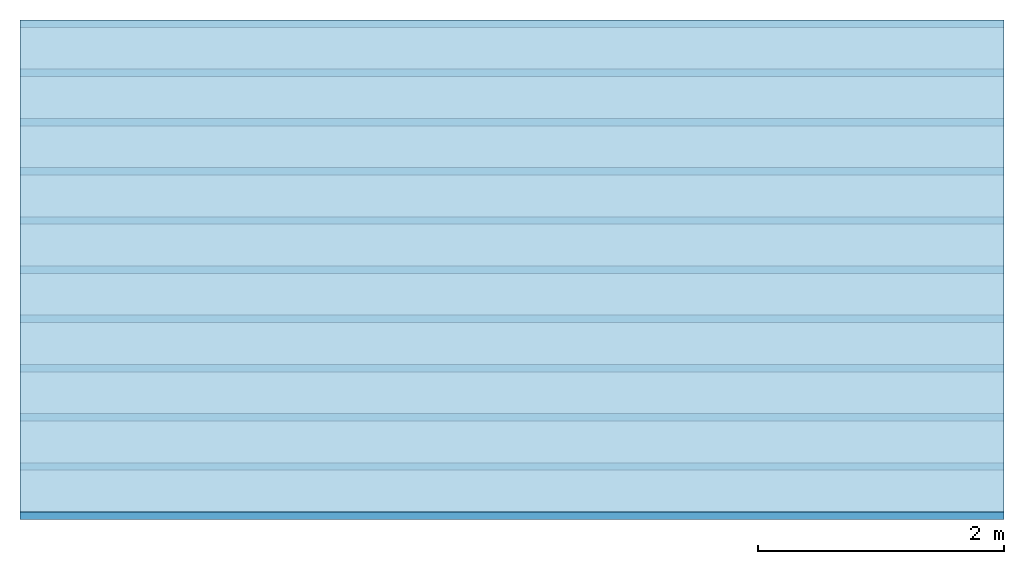
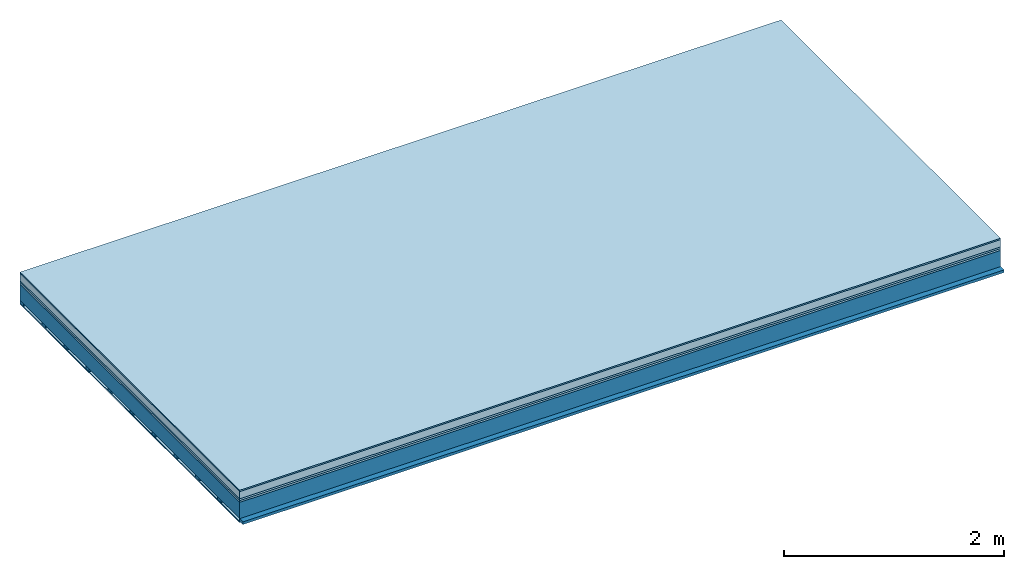
# One storey: 6 plates, 2 members, 1 element without a shape of its own.
"""IFC4 building model written with IfcOpenShell, lengths in metres."""

from ifc_helpers import new_model, si_unit, derived_unit, direction, frame, frame_2d, origin, origin_with_axes, place, context, project, spatial, rectangle, extrude, material, layer, layer_set, type_object, element, aggregate, save


model = new_model("IFC4")

# Units and contexts
plan_context = context("Plan", 3, precision=1e-05, world=origin(), true_north=direction((0.0, 1.0)))
model_context = context("Model", 3, precision=1e-05, world=origin(), true_north=direction((0.0, 1.0)))
ifc_project = project(units=[si_unit("LENGTHUNIT", "METRE"), derived_unit("SOUNDPRESSUREUNIT", [(si_unit("PRESSUREUNIT", "PASCAL", prefix="MICRO"), 0)]), si_unit("ENERGYUNIT", "JOULE", prefix="MEGA"), si_unit("MASSUNIT", "GRAM", prefix="KILO"), derived_unit("THERMALTRANSMITTANCEUNIT", [(si_unit("POWERUNIT", "WATT"), 1), (si_unit("AREAUNIT", "SQUARE_METRE"), -1), (si_unit("THERMODYNAMICTEMPERATUREUNIT", "KELVIN"), -1)]), derived_unit("AREADENSITYUNIT", [(si_unit("MASSUNIT", "GRAM", prefix="KILO"), 1), (si_unit("AREAUNIT", "SQUARE_METRE"), -1)]), derived_unit("USERDEFINED", [(si_unit("ENERGYUNIT", "JOULE", prefix="MEGA"), 1), (si_unit("AREAUNIT", "SQUARE_METRE"), -1)])], contexts=[plan_context, model_context])

# Site, building, storey
site = spatial("IfcSite", under=ifc_project)
building_placement = place(None, origin())
building = spatial("IfcBuilding", under=site, at=building_placement)
storey_placement = place(building_placement, origin())
storey = spatial("IfcBuildingStorey", under=building, at=storey_placement)

# Slab, members, plates
ifc_material_1 = material(Category="11.013")
ifc_layer_1 = layer(ifc_material_1, 0.015, Name="Flooring")
ifc_material_2 = material(Name="Cement screed", Category="04.006")
ifc_layer_2 = layer(ifc_material_2, 0.08, Name="On-material")
ifc_material_3 = material(Name="Wood fiber generic product", Category="10.009")
ifc_layer_3 = layer(ifc_material_3, 0.02, Name="Impact sound insulation")
ifc_material_4 = material(Category="10.004")
ifc_layer_4 = layer(ifc_material_4, 0.02, Name="Additional insulation")
ifc_material_5 = material(Name="no composite action")
ifc_layer_5 = layer(ifc_material_5, 0.0, Name="Bond")
ifc_layer_6 = layer(None, 0.18, Name="Supporting structure")
ifc_material_6 = material(Name="of the art")
ifc_layer_7 = layer(ifc_material_6, 0.0, Name="Bond")
ifc_layer_8 = layer(None, 0.03, Name="Battens / profiles")
ifc_material_7 = material(Name="Plasterboard type A", Category="03.008")
ifc_layer_9 = layer(ifc_material_7, 0.0125, Name="Ceiling covering 1st layer")
ifc_material_8 = material(Category="04.001")
ifc_layer_10 = layer(ifc_material_8, 0.003, Name="Surface / treatment")
ifc_layer_set = layer_set([ifc_layer_1, ifc_layer_2, ifc_layer_3, ifc_layer_4, ifc_layer_5, ifc_layer_6, ifc_layer_7, ifc_layer_8, ifc_layer_9, ifc_layer_10])
slab_type = type_object("IfcSlabType", Name="A2144", PredefinedType="NOTDEFINED", material=ifc_layer_set)
slab_placement = place(None, frame((0.0, 0.0, 0.0), z_axis=(0.0, 0.0, -1.0), x_axis=(1.0, 0.0, 0.0)))
slab = element("IfcSlab", 1, at=slab_placement, inside=storey, type_object=slab_type, material=ifc_layer_set, Name="Slab #1")
ifc_material_9 = material(Name="Solid timber panel")
member_1_placement = place(slab_placement, origin())
member_1 = element("IfcMember", 2, at=member_1_placement, material=ifc_material_9, Name="Supporting structure", context=plan_context, shape_type="SweptSolid", body=[
    extrude(rectangle(XDim=1.0, YDim=0.18, at=frame_2d((0.5, 0.09), x_axis=(1.0, 0.0))), frame((0.0, 4.0, 0.135), z_axis=(0.0, -1.0, 0.0), x_axis=(1.0, 0.0, 0.0)), (0.0, 0.0, 1.0), 4.0),
    extrude(rectangle(XDim=1.0, YDim=0.18, at=frame_2d((0.5, 0.09), x_axis=(1.0, 0.0))), frame((1.0, 4.0, 0.135), z_axis=(0.0, -1.0, 0.0), x_axis=(1.0, 0.0, 0.0)), (0.0, 0.0, 1.0), 4.0),
    extrude(rectangle(XDim=1.0, YDim=0.18, at=frame_2d((0.5, 0.09), x_axis=(1.0, 0.0))), frame((2.0, 4.0, 0.135), z_axis=(0.0, -1.0, 0.0), x_axis=(1.0, 0.0, 0.0)), (0.0, 0.0, 1.0), 4.0),
    extrude(rectangle(XDim=1.0, YDim=0.18, at=frame_2d((0.5, 0.09), x_axis=(1.0, 0.0))), frame((3.0, 4.0, 0.135), z_axis=(0.0, -1.0, 0.0), x_axis=(1.0, 0.0, 0.0)), (0.0, 0.0, 1.0), 4.0),
    extrude(rectangle(XDim=1.0, YDim=0.18, at=frame_2d((0.5, 0.09), x_axis=(1.0, 0.0))), frame((4.0, 4.0, 0.135), z_axis=(0.0, -1.0, 0.0), x_axis=(1.0, 0.0, 0.0)), (0.0, 0.0, 1.0), 4.0),
    extrude(rectangle(XDim=1.0, YDim=0.18, at=frame_2d((0.5, 0.09), x_axis=(1.0, 0.0))), frame((5.0, 4.0, 0.135), z_axis=(0.0, -1.0, 0.0), x_axis=(1.0, 0.0, 0.0)), (0.0, 0.0, 1.0), 4.0),
    extrude(rectangle(XDim=1.0, YDim=0.18, at=frame_2d((0.5, 0.09), x_axis=(1.0, 0.0))), frame((6.0, 4.0, 0.135), z_axis=(0.0, -1.0, 0.0), x_axis=(1.0, 0.0, 0.0)), (0.0, 0.0, 1.0), 4.0),
    extrude(rectangle(XDim=1.0, YDim=0.18, at=frame_2d((0.5, 0.09), x_axis=(1.0, 0.0))), frame((7.0, 4.0, 0.135), z_axis=(0.0, -1.0, 0.0), x_axis=(1.0, 0.0, 0.0)), (0.0, 0.0, 1.0), 4.0),
])
ifc_material_10 = material()
member_2_placement = place(slab_placement, origin())
member_2 = element("IfcMember", 3, at=member_2_placement, material=ifc_material_10, Name="Battens / profiles", context=plan_context, shape_type="SweptSolid", body=[
    extrude(rectangle(XDim=0.06, YDim=0.03, at=frame_2d((0.03, 0.015), x_axis=(1.0, 0.0))), frame((0.0, 0.0, 0.315), z_axis=(1.0, 0.0, 0.0), x_axis=(0.0, 1.0, 0.0)), (0.0, 0.0, 1.0), 8.0),
    extrude(rectangle(XDim=0.06, YDim=0.03, at=frame_2d((0.03, 0.015), x_axis=(1.0, 0.0))), frame((0.0, 0.4, 0.315), z_axis=(1.0, 0.0, 0.0), x_axis=(0.0, 1.0, 0.0)), (0.0, 0.0, 1.0), 8.0),
    extrude(rectangle(XDim=0.06, YDim=0.03, at=frame_2d((0.03, 0.015), x_axis=(1.0, 0.0))), frame((0.0, 0.8, 0.315), z_axis=(1.0, 0.0, 0.0), x_axis=(0.0, 1.0, 0.0)), (0.0, 0.0, 1.0), 8.0),
    extrude(rectangle(XDim=0.06, YDim=0.03, at=frame_2d((0.03, 0.015), x_axis=(1.0, 0.0))), frame((0.0, 1.2, 0.315), z_axis=(1.0, 0.0, 0.0), x_axis=(0.0, 1.0, 0.0)), (0.0, 0.0, 1.0), 8.0),
    extrude(rectangle(XDim=0.06, YDim=0.03, at=frame_2d((0.03, 0.015), x_axis=(1.0, 0.0))), frame((0.0, 1.6, 0.315), z_axis=(1.0, 0.0, 0.0), x_axis=(0.0, 1.0, 0.0)), (0.0, 0.0, 1.0), 8.0),
    extrude(rectangle(XDim=0.06, YDim=0.03, at=frame_2d((0.03, 0.015), x_axis=(1.0, 0.0))), frame((0.0, 2.0, 0.315), z_axis=(1.0, 0.0, 0.0), x_axis=(0.0, 1.0, 0.0)), (0.0, 0.0, 1.0), 8.0),
    extrude(rectangle(XDim=0.06, YDim=0.03, at=frame_2d((0.03, 0.015), x_axis=(1.0, 0.0))), frame((0.0, 2.4, 0.315), z_axis=(1.0, 0.0, 0.0), x_axis=(0.0, 1.0, 0.0)), (0.0, 0.0, 1.0), 8.0),
    extrude(rectangle(XDim=0.06, YDim=0.03, at=frame_2d((0.03, 0.015), x_axis=(1.0, 0.0))), frame((0.0, 2.8, 0.315), z_axis=(1.0, 0.0, 0.0), x_axis=(0.0, 1.0, 0.0)), (0.0, 0.0, 1.0), 8.0),
    extrude(rectangle(XDim=0.06, YDim=0.03, at=frame_2d((0.03, 0.015), x_axis=(1.0, 0.0))), frame((0.0, 3.2, 0.315), z_axis=(1.0, 0.0, 0.0), x_axis=(0.0, 1.0, 0.0)), (0.0, 0.0, 1.0), 8.0),
    extrude(rectangle(XDim=0.06, YDim=0.03, at=frame_2d((0.03, 0.015), x_axis=(1.0, 0.0))), frame((0.0, 3.6, 0.315), z_axis=(1.0, 0.0, 0.0), x_axis=(0.0, 1.0, 0.0)), (0.0, 0.0, 1.0), 8.0),
    extrude(rectangle(XDim=0.06, YDim=0.03, at=frame_2d((0.03, 0.015), x_axis=(1.0, 0.0))), frame((0.0, 4.0, 0.315), z_axis=(1.0, 0.0, 0.0), x_axis=(0.0, 1.0, 0.0)), (0.0, 0.0, 1.0), 8.0),
])
plate_1_placement = place(slab_placement, origin())
plate_1 = element("IfcPlate", 4, at=plate_1_placement, material=ifc_material_1, Name="Flooring", context=plan_context, shape_type="SweptSolid", body=[
    extrude(rectangle(XDim=8.0, YDim=4.0, at=frame_2d((4.0, 2.0), x_axis=(1.0, 0.0))), origin_with_axes(), (0.0, 0.0, 1.0), 0.015),
])
plate_2_placement = place(slab_placement, origin())
plate_2 = element("IfcPlate", 5, at=plate_2_placement, material=ifc_material_2, Name="On-material", context=plan_context, shape_type="SweptSolid", body=[
    extrude(rectangle(XDim=8.0, YDim=4.0, at=frame_2d((4.0, 2.0), x_axis=(1.0, 0.0))), frame((0.0, 0.0, 0.015), z_axis=(0.0, 0.0, 1.0), x_axis=(1.0, 0.0, 0.0)), (0.0, 0.0, 1.0), 0.08),
])
plate_3_placement = place(slab_placement, origin())
plate_3 = element("IfcPlate", 6, at=plate_3_placement, material=ifc_material_3, Name="Impact sound insulation", context=plan_context, shape_type="SweptSolid", body=[
    extrude(rectangle(XDim=8.0, YDim=4.0, at=frame_2d((4.0, 2.0), x_axis=(1.0, 0.0))), frame((0.0, 0.0, 0.095), z_axis=(0.0, 0.0, 1.0), x_axis=(1.0, 0.0, 0.0)), (0.0, 0.0, 1.0), 0.02),
])
plate_4_placement = place(slab_placement, origin())
plate_4 = element("IfcPlate", 7, at=plate_4_placement, material=ifc_material_4, Name="Additional insulation", context=plan_context, shape_type="SweptSolid", body=[
    extrude(rectangle(XDim=8.0, YDim=4.0, at=frame_2d((4.0, 2.0), x_axis=(1.0, 0.0))), frame((0.0, 0.0, 0.115), z_axis=(0.0, 0.0, 1.0), x_axis=(1.0, 0.0, 0.0)), (0.0, 0.0, 1.0), 0.02),
])
plate_5_placement = place(slab_placement, origin())
plate_5 = element("IfcPlate", 8, at=plate_5_placement, material=ifc_material_7, Name="Ceiling covering 1st layer", context=plan_context, shape_type="SweptSolid", body=[
    extrude(rectangle(XDim=8.0, YDim=4.0, at=frame_2d((4.0, 2.0), x_axis=(1.0, 0.0))), frame((0.0, 0.0, 0.345), z_axis=(0.0, 0.0, 1.0), x_axis=(1.0, 0.0, 0.0)), (0.0, 0.0, 1.0), 0.0125),
])
plate_6_placement = place(slab_placement, origin())
plate_6 = element("IfcPlate", 9, at=plate_6_placement, material=ifc_material_8, Name="Surface / treatment", context=plan_context, shape_type="SweptSolid", body=[
    extrude(rectangle(XDim=8.0, YDim=4.0, at=frame_2d((4.0, 2.0), x_axis=(1.0, 0.0))), frame((0.0, 0.0, 0.3575), z_axis=(0.0, 0.0, 1.0), x_axis=(1.0, 0.0, 0.0)), (0.0, 0.0, 1.0), 0.003),
])
aggregate(slab, [plate_1, plate_2, plate_3, plate_4, member_1, member_2, plate_5, plate_6])

save(model, "model.ifc")
